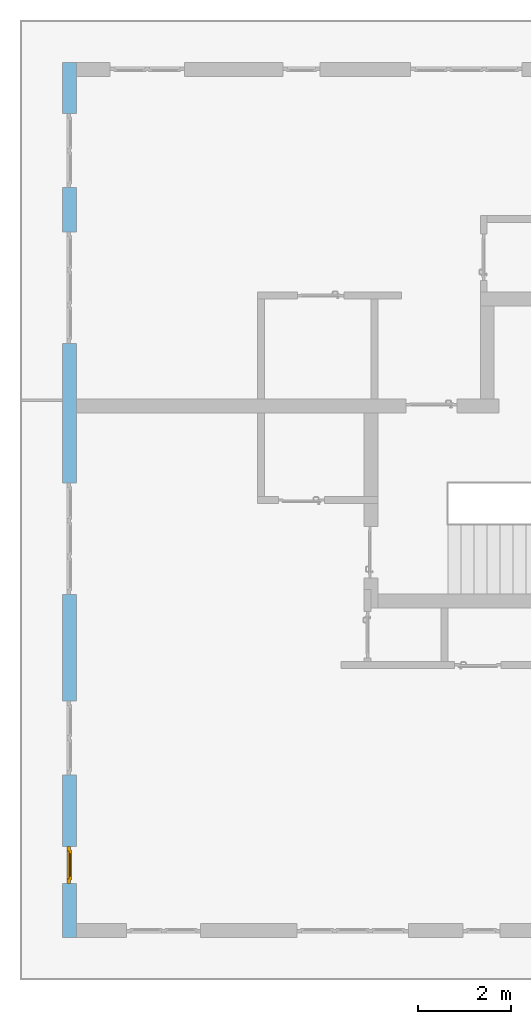
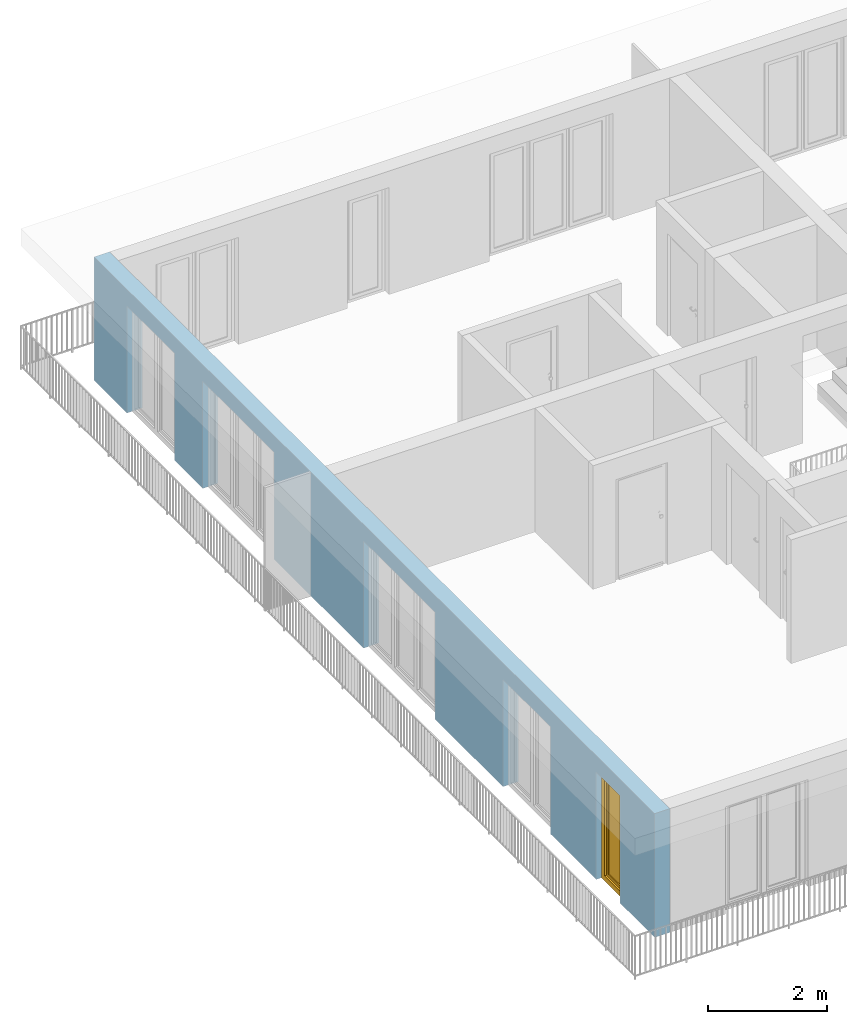
# One storey, part 8 of 48: 1 window, 5 openings, plus 1 element that does not belong to this part.
"""IFC4 building model written with IfcOpenShell, lengths in metres."""

from ifc_helpers import new_model, entity, si_unit, converted_unit, derived_unit, direction, frame, origin_with_axes, place, context, subcontext, project, spatial, polygons, source, transform, mapped, material, type_object, element, fill, save


model = new_model("IFC4")

# Units and contexts
model_context = context("Model", 3, precision=1e-05, world=origin_with_axes(), true_north=direction((0.0, 1.0)))
body_context = subcontext(model_context, "Body", "Model", "MODEL_VIEW")
ifc_project = project(units=[si_unit("LENGTHUNIT", "METRE"), si_unit("AREAUNIT", "SQUARE_METRE"), si_unit("VOLUMEUNIT", "CUBIC_METRE"), converted_unit("PLANEANGLEUNIT", "DEGREE", entity("IfcPlaneAngleMeasure", 0.0174532925199), si_unit("PLANEANGLEUNIT", "RADIAN"), dimensions=[0, 0, 0, 0, 0, 0, 0]), converted_unit("TIMEUNIT", "Year", entity("IfcTimeMeasure", 31556926.0), si_unit("TIMEUNIT", "SECOND"), dimensions=[0, 0, 1, 0, 0, 0, 0]), si_unit("MASSUNIT", "GRAM", prefix="KILO"), si_unit("THERMODYNAMICTEMPERATUREUNIT", "DEGREE_CELSIUS"), si_unit("LUMINOUSINTENSITYUNIT", "LUMEN"), si_unit("ENERGYUNIT", "JOULE", prefix="MEGA"), derived_unit("THERMALCONDUCTANCEUNIT", [(si_unit("POWERUNIT", "WATT"), 1), (si_unit("LENGTHUNIT", "METRE"), -1), (si_unit("THERMODYNAMICTEMPERATUREUNIT", "KELVIN"), -1)]), derived_unit("SPECIFICHEATCAPACITYUNIT", [(si_unit("ENERGYUNIT", "JOULE"), 1), (si_unit("MASSUNIT", "GRAM", prefix="KILO"), -1), (si_unit("THERMODYNAMICTEMPERATUREUNIT", "KELVIN"), -1)]), derived_unit("MASSDENSITYUNIT", [(si_unit("MASSUNIT", "GRAM", prefix="KILO"), 1), (si_unit("VOLUMEUNIT", "CUBIC_METRE"), -1)])], contexts=[model_context])

# Site, building, storey
site_placement = place(None, origin_with_axes())
site = spatial("IfcSite", under=ifc_project, at=site_placement, CompositionType="ELEMENT")
building_placement = place(site_placement, origin_with_axes())
building = spatial("IfcBuilding", under=site, at=building_placement, CompositionType="ELEMENT")
storey_placement = place(building_placement, frame((0.0, 0.0, 3.4), z_axis=(0.0, 0.0, 1.0), x_axis=(1.0, 0.0, 0.0)))
storey = spatial("IfcBuildingStorey", under=building, at=storey_placement, Name="1. Geschoss", CompositionType="ELEMENT", Elevation=3.4)

# Wall, openings, window
ifc_material = material()
wall_type = type_object("IfcWallType", Name="300", PredefinedType="NOTDEFINED")
wall_placement = place(storey_placement, frame((-11.7421993804, -9.92881223104, 0.0), z_axis=(0.0, 0.0, 1.0), x_axis=(0.0, 1.0, 0.0)))
wall = element("IfcWall", 1, at=wall_placement, inside=storey, type_object=wall_type, material=ifc_material, Name="Wand-001", PredefinedType="NOTDEFINED", context=body_context, shape_type="Tessellation", body=[
    polygons([(1.16441876325, -0.3, 0.0), (1.16441876325, -0.3, 2.2), (1.96441876325, -0.3, 2.2), (1.96441876325, -0.3, 0.0), (3.5, -0.3, 0.0), (3.5, -0.3, 2.2), (5.1, -0.3, 2.2), (5.1, -0.3, 0.0), (7.3921181063, -0.3, 0.0), (7.3921181063, -0.3, 2.2), (9.7921181063, -0.3, 2.2), (9.7921181063, -0.3, 0.0), (12.8, -0.3, 0.0), (12.8, -0.3, 2.2), (15.2, -0.3, 2.2), (15.2, -0.3, 0.0), (16.15, -0.3, 0.0), (16.15, -0.3, 2.2), (17.75, -0.3, 2.2), (17.75, -0.3, 0.0), (18.85, -0.3, 0.0), (18.85, -0.3, 2.54), (0.0, -0.3, 2.54), (0.0, -0.3, 0.0), (1.16441876325, -0.1, 0.0), (1.16441876325, -0.1, 2.2), (1.96441876325, -0.1, 2.2), (1.96441876325, -0.1, 0.0), (1.96441876325, 0.0, 0.0), (3.5, 0.0, 0.0), (3.5, -0.1, 0.0), (3.5, -0.1, 2.2), (5.1, -0.1, 2.2), (5.1, -0.1, 0.0), (5.1, 0.0, 0.0), (7.3921181063, 0.0, 0.0), (7.3921181063, -0.1, 0.0), (7.3921181063, -0.1, 2.2), (9.7921181063, -0.1, 2.2), (9.7921181063, -0.1, 0.0), (9.7921181063, 0.0, 0.0), (12.8, 0.0, 0.0), (12.8, -0.1, 0.0), (12.8, -0.1, 2.2), (15.2, -0.1, 2.2), (15.2, -0.1, 0.0), (15.2, 0.0, 0.0), (16.15, 0.0, 0.0), (16.15, -0.1, 0.0), (16.15, -0.1, 2.2), (17.75, -0.1, 2.2), (17.75, -0.1, 0.0), (17.75, 0.0, 0.0), (18.85, 0.0, 0.0), (18.85, 0.0, 2.54), (0.0, 0.0, 2.54), (0.0, 0.0, 0.0), (1.16441876325, 0.0, 0.0), (1.16441876325, 0.0, 2.2), (1.96441876325, 0.0, 2.2), (17.75, 0.0, 2.2), (16.15, 0.0, 2.2), (15.2, 0.0, 2.2), (12.8, 0.0, 2.2), (9.7921181063, 0.0, 2.2), (7.3921181063, 0.0, 2.2), (5.1, 0.0, 2.2), (3.5, 0.0, 2.2)], [[[1, 2, 3, 4, 5, 6, 7, 8, 9, 10, 11, 12, 13, 14, 15, 16, 17, 18, 19, 20, 21, 22, 23, 24]], [[2, 1, 25, 26]], [[3, 2, 26, 27]], [[4, 3, 27, 28]], [[4, 28, 29, 30, 31, 5]], [[31, 32, 6, 5]], [[32, 33, 7, 6]], [[33, 34, 8, 7]], [[8, 34, 35, 36, 37, 9]], [[10, 9, 37, 38]], [[11, 10, 38, 39]], [[12, 11, 39, 40]], [[12, 40, 41, 42, 43, 13]], [[43, 44, 14, 13]], [[44, 45, 15, 14]], [[45, 46, 16, 15]], [[16, 46, 47, 48, 49, 17]], [[18, 17, 49, 50]], [[19, 18, 50, 51]], [[20, 19, 51, 52]], [[52, 53, 54, 21, 20]], [[22, 21, 54, 55]], [[22, 55, 56, 23]], [[56, 57, 24, 23]], [[25, 1, 24, 57, 58]], [[26, 25, 58, 59]], [[27, 26, 59, 60]], [[28, 27, 60, 29]], [[30, 29, 60, 59, 58, 57, 56, 55, 54, 53, 61, 62, 48, 47, 63, 64, 42, 41, 65, 66, 36, 35, 67, 68]], [[30, 68, 32, 31]], [[68, 67, 33, 32]], [[67, 35, 34, 33]], [[38, 37, 36, 66]], [[39, 38, 66, 65]], [[40, 39, 65, 41]], [[42, 64, 44, 43]], [[64, 63, 45, 44]], [[63, 47, 46, 45]], [[50, 49, 48, 62]], [[51, 50, 62, 61]], [[52, 51, 61, 53]]], closed=True),
])
opening_1_placement = place(wall_placement, frame((16.95, 0.0, 0.0), z_axis=(0.0, 0.0, 1.0), x_axis=(1.0, 0.0, 0.0)))
element("IfcOpeningElement", 2, at=opening_1_placement, cuts=wall, Name="Fenster-001", context=body_context, identifier="Reference", shape_type="Tessellation", body=[
    polygons([(-0.8, -0.1, 0.0), (-0.8, -0.1, 2.2), (-0.8, 0.000999999999999, 2.2), (-0.8, 0.000999999999999, 0.0), (-0.8, -0.301, 0.0), (-0.8, -0.301, 2.2), (0.8, -0.1, 2.2), (0.8, 0.000999999999999, 2.2), (0.8, -0.301, 2.2), (0.8, 0.000999999999999, 0.0), (0.8, -0.1, 0.0), (0.8, -0.301, 0.0)], [[[1, 2, 3, 4]], [[2, 1, 5, 6]], [[7, 8, 3, 2, 6, 9]], [[8, 10, 4, 3]], [[1, 4, 10, 11, 12, 5]], [[6, 5, 12, 9]], [[7, 11, 10, 8]], [[11, 7, 9, 12]]], closed=True),
])
opening_2_placement = place(wall_placement, frame((14.0, 0.0, 0.0), z_axis=(0.0, 0.0, 1.0), x_axis=(1.0, 0.0, 0.0)))
element("IfcOpeningElement", 3, at=opening_2_placement, cuts=wall, Name="Fenster-002", context=body_context, identifier="Reference", shape_type="Tessellation", body=[
    polygons([(-1.2, -0.1, 0.0), (-1.2, -0.1, 2.2), (-1.2, 0.000999999999999, 2.2), (-1.2, 0.000999999999999, 0.0), (-1.2, -0.301, 0.0), (-1.2, -0.301, 2.2), (1.2, -0.1, 2.2), (1.2, 0.000999999999999, 2.2), (1.2, -0.301, 2.2), (1.2, 0.000999999999999, 0.0), (1.2, -0.1, 0.0), (1.2, -0.301, 0.0)], [[[1, 2, 3, 4]], [[2, 1, 5, 6]], [[7, 8, 3, 2, 6, 9]], [[8, 10, 4, 3]], [[1, 4, 10, 11, 12, 5]], [[6, 5, 12, 9]], [[7, 11, 10, 8]], [[11, 7, 9, 12]]], closed=True),
])
opening_3_placement = place(wall_placement, frame((8.5921181063, 0.0, 0.0), z_axis=(0.0, 0.0, 1.0), x_axis=(1.0, 0.0, 0.0)))
element("IfcOpeningElement", 4, at=opening_3_placement, cuts=wall, Name="Fenster-002", context=body_context, identifier="Reference", shape_type="Tessellation", body=[
    polygons([(-1.2, -0.1, 0.0), (-1.2, -0.1, 2.2), (-1.2, 0.000999999999999, 2.2), (-1.2, 0.000999999999999, 0.0), (-1.2, -0.301, 0.0), (-1.2, -0.301, 2.2), (1.2, -0.1, 2.2), (1.2, 0.000999999999999, 2.2), (1.2, -0.301, 2.2), (1.2, 0.000999999999999, 0.0), (1.2, -0.1, 0.0), (1.2, -0.301, 0.0)], [[[1, 2, 3, 4]], [[2, 1, 5, 6]], [[7, 8, 3, 2, 6, 9]], [[8, 10, 4, 3]], [[1, 4, 10, 11, 12, 5]], [[6, 5, 12, 9]], [[7, 11, 10, 8]], [[11, 7, 9, 12]]], closed=True),
])
opening_4_placement = place(wall_placement, frame((4.3, 0.0, 0.0), z_axis=(0.0, 0.0, 1.0), x_axis=(1.0, 0.0, 0.0)))
element("IfcOpeningElement", 5, at=opening_4_placement, cuts=wall, Name="Fenster-001", context=body_context, identifier="Reference", shape_type="Tessellation", body=[
    polygons([(-0.8, -0.1, 0.0), (-0.8, -0.1, 2.2), (-0.8, 0.000999999999999, 2.2), (-0.8, 0.000999999999999, 0.0), (-0.8, -0.301, 0.0), (-0.8, -0.301, 2.2), (0.8, -0.1, 2.2), (0.8, 0.000999999999999, 2.2), (0.8, -0.301, 2.2), (0.8, 0.000999999999999, 0.0), (0.8, -0.1, 0.0), (0.8, -0.301, 0.0)], [[[1, 2, 3, 4]], [[2, 1, 5, 6]], [[7, 8, 3, 2, 6, 9]], [[8, 10, 4, 3]], [[1, 4, 10, 11, 12, 5]], [[6, 5, 12, 9]], [[7, 11, 10, 8]], [[11, 7, 9, 12]]], closed=True),
])
opening_5_placement = place(wall_placement, frame((1.56441876325, 0.0, 0.0), z_axis=(0.0, 0.0, 1.0), x_axis=(1.0, 0.0, 0.0)))
opening_5 = element("IfcOpeningElement", 6, at=opening_5_placement, cuts=wall, Name="Fenster-003", context=body_context, identifier="Reference", shape_type="Tessellation", body=[
    polygons([(-0.4, -0.1, 0.0), (-0.4, -0.1, 2.2), (-0.4, 0.000999999999999, 2.2), (-0.4, 0.000999999999999, 0.0), (-0.4, -0.301, 0.0), (-0.4, -0.301, 2.2), (0.4, -0.1, 2.2), (0.4, 0.000999999999999, 2.2), (0.4, -0.301, 2.2), (0.4, 0.000999999999999, 0.0), (0.4, -0.1, 0.0), (0.4, -0.301, 0.0)], [[[1, 2, 3, 4]], [[2, 1, 5, 6]], [[7, 8, 3, 2, 6, 9]], [[8, 10, 4, 3]], [[1, 4, 10, 11, 12, 5]], [[6, 5, 12, 9]], [[7, 11, 10, 8]], [[11, 7, 9, 12]]], closed=True),
])
window_type = type_object("IfcWindowType", Name="1-26", PartitioningType="SINGLE_PANEL", PredefinedType="WINDOW")
shared_shape = source(origin_with_axes(), body_context, "Body", "Tessellation", [
    polygons([(-0.4, -0.07, 0.0), (-0.4, 0.0, 0.0), (-0.3, 0.0, 0.1), (-0.3, -0.07, 0.1), (-0.4, -0.07, 2.2), (-0.4, 0.0, 2.2), (-0.3, 0.0, 2.1), (-0.3, -0.07, 2.1)], [[[1, 2, 3, 4]], [[5, 6, 2, 1]], [[2, 6, 7, 3]], [[4, 3, 7, 8]], [[1, 4, 8, 5]], [[8, 7, 6, 5]]], closed=True),
    polygons([(0.4, -0.07, 0.0), (0.4, 0.0, 0.0), (0.4, 0.0, 2.2), (0.4, -0.07, 2.2), (0.3, -0.07, 0.1), (0.3, 0.0, 0.1), (0.3, 0.0, 2.1), (0.3, -0.07, 2.1)], [[[1, 2, 3, 4]], [[5, 6, 2, 1]], [[2, 6, 7, 3]], [[4, 3, 7, 8]], [[1, 4, 8, 5]], [[8, 7, 6, 5]]], closed=True),
    polygons([(-0.4, -0.07, 0.0), (-0.4, 0.0, 0.0), (0.4, 0.0, 0.0), (0.4, -0.07, 0.0), (-0.3, -0.07, 0.1), (-0.3, 0.0, 0.1), (0.0, 0.0, 0.1), (0.3, 0.0, 0.1), (0.3, -0.07, 0.1), (0.0, -0.07, 0.1)], [[[1, 2, 3, 4]], [[5, 6, 2, 1]], [[2, 6, 7, 8, 3]], [[4, 3, 8, 9]], [[1, 4, 9, 10, 5]], [[10, 7, 6, 5]], [[9, 8, 7, 10]]], closed=True),
    polygons([(-0.4, -0.07, 2.2), (-0.4, 0.0, 2.2), (-0.3, 0.0, 2.1), (-0.3, -0.07, 2.1), (0.4, -0.07, 2.2), (0.4, 0.0, 2.2), (0.3, 0.0, 2.1), (0.0, 0.0, 2.1), (0.0, -0.07, 2.1), (0.3, -0.07, 2.1)], [[[1, 2, 3, 4]], [[5, 6, 2, 1]], [[2, 6, 7, 8, 3]], [[4, 3, 8, 9]], [[1, 4, 9, 10, 5]], [[10, 7, 6, 5]], [[9, 8, 7, 10]]], closed=True),
    polygons([(-0.32, 0.0, 0.08), (-0.32, 0.03, 0.08), (-0.25, 0.03, 0.15), (-0.25, 0.0, 0.15), (-0.32, 0.0, 2.12), (-0.32, 0.03, 2.12), (-0.25, 0.03, 2.05), (-0.25, 0.0, 2.05)], [[[1, 2, 3, 4]], [[5, 6, 2, 1]], [[2, 6, 7, 3]], [[4, 3, 7, 8]], [[1, 4, 8, 5]], [[8, 7, 6, 5]]], closed=True),
    polygons([(0.32, 0.0, 0.08), (0.25, 0.0, 0.15), (0.25, 0.03, 0.15), (0.32, 0.03, 0.08), (0.32, 0.0, 2.12), (0.25, 0.0, 2.05), (0.25, 0.03, 2.05), (0.32, 0.03, 2.12)], [[[1, 2, 3, 4]], [[1, 5, 6, 2]], [[2, 6, 7, 3]], [[4, 3, 7, 8]], [[5, 1, 4, 8]], [[6, 5, 8, 7]]], closed=True),
    polygons([(-0.32, 0.0, 0.08), (-0.32, 0.03, 0.08), (0.32, 0.03, 0.08), (0.32, 0.0, 0.08), (-0.25, 0.0, 0.15), (-0.25, 0.03, 0.15), (0.25, 0.03, 0.15), (0.25, 0.0, 0.15)], [[[1, 2, 3, 4]], [[5, 6, 2, 1]], [[2, 6, 7, 3]], [[4, 3, 7, 8]], [[1, 4, 8, 5]], [[8, 7, 6, 5]]], closed=True),
    polygons([(-0.32, 0.0, 2.12), (0.32, 0.0, 2.12), (0.32, 0.03, 2.12), (-0.32, 0.03, 2.12), (-0.25, 0.0, 2.05), (0.25, 0.0, 2.05), (0.25, 0.03, 2.05), (-0.25, 0.03, 2.05)], [[[1, 2, 3, 4]], [[1, 5, 6, 2]], [[2, 6, 7, 3]], [[4, 3, 7, 8]], [[5, 1, 4, 8]], [[6, 5, 8, 7]]], closed=True),
    polygons([(-0.3, -0.03, 0.1), (-0.3, 0.0, 0.1), (-0.25, 0.0, 0.15), (-0.25, -0.03, 0.15), (-0.3, -0.03, 2.1), (-0.3, 0.0, 2.1), (-0.25, 0.0, 2.05), (-0.25, -0.03, 2.05)], [[[1, 2, 3, 4]], [[5, 6, 2, 1]], [[2, 6, 7, 3]], [[4, 3, 7, 8]], [[1, 4, 8, 5]], [[8, 7, 6, 5]]], closed=True),
    polygons([(0.3, -0.03, 0.1), (0.25, -0.03, 0.15), (0.25, 0.0, 0.15), (0.3, 0.0, 0.1), (0.3, -0.03, 2.1), (0.25, -0.03, 2.05), (0.25, 0.0, 2.05), (0.3, 0.0, 2.1)], [[[1, 2, 3, 4]], [[1, 5, 6, 2]], [[2, 6, 7, 3]], [[4, 3, 7, 8]], [[5, 1, 4, 8]], [[6, 5, 8, 7]]], closed=True),
    polygons([(-0.3, -0.03, 0.1), (-0.3, 0.0, 0.1), (0.3, 0.0, 0.1), (0.3, -0.03, 0.1), (-0.25, -0.03, 0.15), (-0.25, 0.0, 0.15), (0.25, 0.0, 0.15), (0.25, -0.03, 0.15)], [[[1, 2, 3, 4]], [[5, 6, 2, 1]], [[2, 6, 7, 3]], [[4, 3, 7, 8]], [[1, 4, 8, 5]], [[8, 7, 6, 5]]], closed=True),
    polygons([(-0.3, -0.03, 2.1), (0.3, -0.03, 2.1), (0.3, 0.0, 2.1), (-0.3, 0.0, 2.1), (-0.25, -0.03, 2.05), (0.25, -0.03, 2.05), (0.25, 0.0, 2.05), (-0.25, 0.0, 2.05)], [[[1, 2, 3, 4]], [[1, 5, 6, 2]], [[2, 6, 7, 3]], [[4, 3, 7, 8]], [[5, 1, 4, 8]], [[6, 5, 8, 7]]], closed=True),
    polygons([(-0.25, -0.005, 0.15), (-0.25, 0.005, 0.15), (0.25, 0.005, 0.15), (0.25, -0.005, 0.15), (-0.25, -0.005, 2.05), (-0.25, 0.005, 2.05), (0.25, 0.005, 2.05), (0.25, -0.005, 2.05)], [[[1, 2, 3, 4]], [[5, 6, 2, 1]], [[2, 6, 7, 3]], [[4, 3, 7, 8]], [[1, 4, 8, 5]], [[8, 7, 6, 5]]], closed=True),
])
window_placement = place(opening_5_placement, frame((0.4, 0.0, 0.0), z_axis=(0.0, 0.0, 1.0), x_axis=(-1.0, 0.0, 0.0)))
window = element("IfcWindow", 7, at=window_placement, inside=storey, type_object=window_type, Name="Fenster-003", OverallHeight=2.2, OverallWidth=0.8, PredefinedType="WINDOW", context=body_context, shape_type="MappedRepresentation", body=[
    mapped(shared_shape, transform((0.4, 0.17, 0.0))),
])
fill(opening_5, window)

save(model, "model.ifc")
